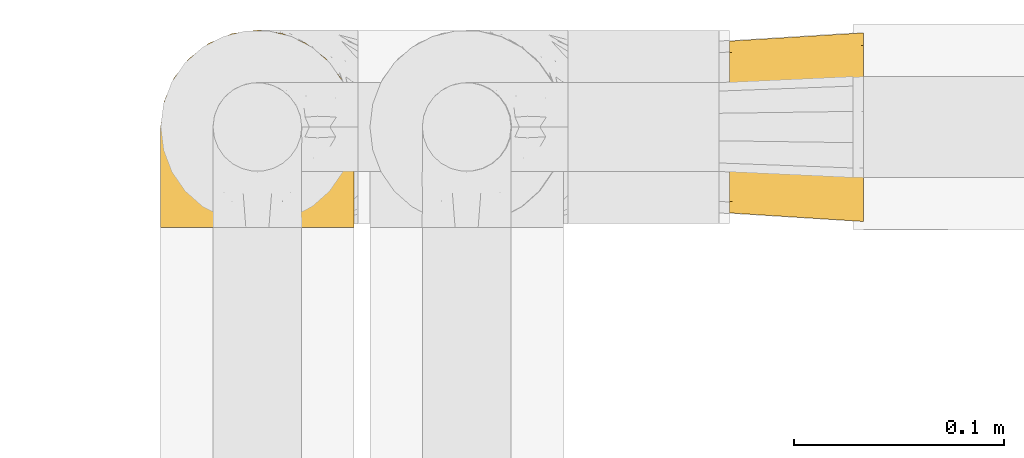
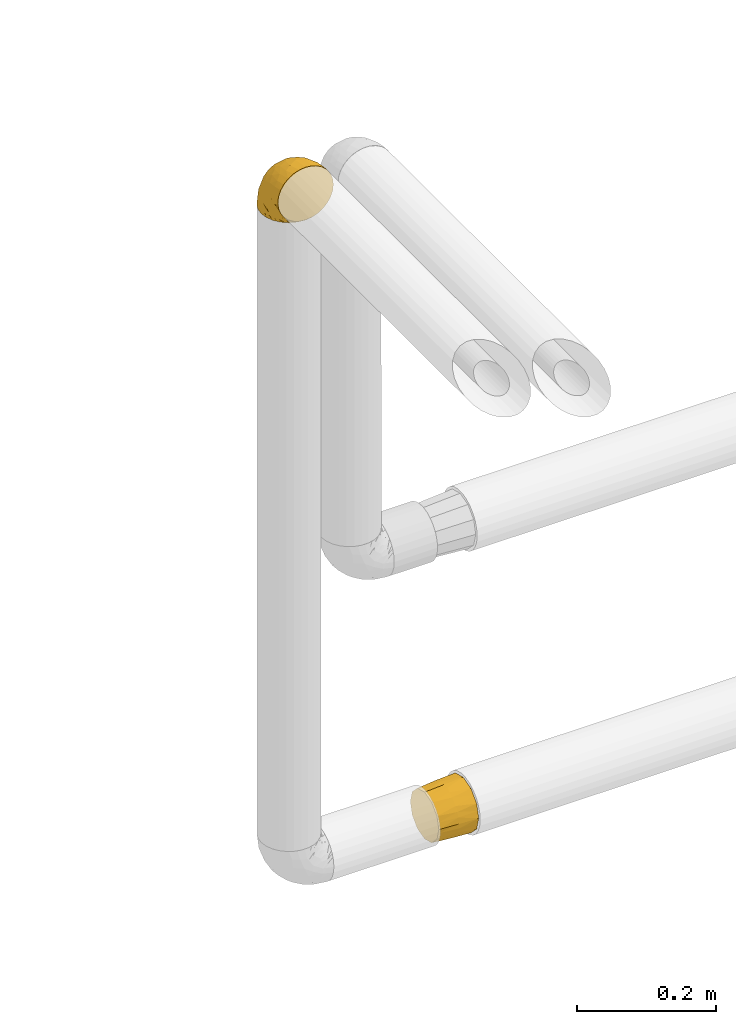
# One storey, part 306 of 827: 2 coverings.
"""IFC2X3 building model written with IfcOpenShell, lengths in millimetres."""

from ifc_helpers import new_model, entity, si_unit, converted_unit, derived_unit, direction, frame, origin, place, context, subcontext, project, spatial, faceted_brep, element, save


model = new_model("IFC2X3")

# Units and contexts
model_context = context("Model", 3, precision=0.01, world=origin(), true_north=direction((6.12303176911189e-17, 1.0)))
body_context = subcontext(model_context, "Body", "Model", "MODEL_VIEW")
ifc_project = project(units=[si_unit("LENGTHUNIT", "METRE", prefix="MILLI"), si_unit("AREAUNIT", "SQUARE_METRE"), si_unit("VOLUMEUNIT", "CUBIC_METRE"), converted_unit("PLANEANGLEUNIT", "DEGREE", entity("IfcRatioMeasure", 0.0174532925199433), si_unit("PLANEANGLEUNIT", "RADIAN"), dimensions=[0, 0, 0, 0, 0, 0, 0]), si_unit("MASSUNIT", "GRAM", prefix="KILO"), derived_unit("MASSDENSITYUNIT", [(si_unit("MASSUNIT", "GRAM", prefix="KILO"), 1), (si_unit("LENGTHUNIT", "METRE"), -3)]), derived_unit("MOMENTOFINERTIAUNIT", [(si_unit("LENGTHUNIT", "METRE"), 4)]), si_unit("TIMEUNIT", "SECOND"), si_unit("FREQUENCYUNIT", "HERTZ"), si_unit("THERMODYNAMICTEMPERATUREUNIT", "DEGREE_CELSIUS"), derived_unit("THERMALTRANSMITTANCEUNIT", [(si_unit("MASSUNIT", "GRAM", prefix="KILO"), 1), (si_unit("THERMODYNAMICTEMPERATUREUNIT", "KELVIN"), -1), (si_unit("TIMEUNIT", "SECOND"), -3)]), derived_unit("VOLUMETRICFLOWRATEUNIT", [(si_unit("LENGTHUNIT", "METRE"), 3), (si_unit("TIMEUNIT", "SECOND"), -1)]), derived_unit("MASSFLOWRATEUNIT", [(si_unit("MASSUNIT", "GRAM", prefix="KILO"), 1), (si_unit("TIMEUNIT", "SECOND"), -1)]), derived_unit("ROTATIONALFREQUENCYUNIT", [(si_unit("TIMEUNIT", "SECOND"), -1)]), si_unit("ELECTRICCURRENTUNIT", "AMPERE"), si_unit("ELECTRICVOLTAGEUNIT", "VOLT"), si_unit("POWERUNIT", "WATT"), si_unit("FORCEUNIT", "NEWTON", prefix="KILO"), si_unit("ILLUMINANCEUNIT", "LUX"), si_unit("LUMINOUSFLUXUNIT", "LUMEN"), si_unit("LUMINOUSINTENSITYUNIT", "CANDELA"), derived_unit("USERDEFINED", [(si_unit("MASSUNIT", "GRAM", prefix="KILO"), -1), (si_unit("LENGTHUNIT", "METRE"), -2), (si_unit("TIMEUNIT", "SECOND"), 3), (si_unit("LUMINOUSFLUXUNIT", "LUMEN"), 1)]), derived_unit("LINEARVELOCITYUNIT", [(si_unit("LENGTHUNIT", "METRE"), 1), (si_unit("TIMEUNIT", "SECOND"), -1)]), si_unit("PRESSUREUNIT", "PASCAL"), derived_unit("USERDEFINED", [(si_unit("LENGTHUNIT", "METRE"), -2), (si_unit("MASSUNIT", "GRAM", prefix="KILO"), 1), (si_unit("TIMEUNIT", "SECOND"), -2)]), derived_unit("LINEARFORCEUNIT", [(si_unit("MASSUNIT", "GRAM", prefix="KILO"), 1), (si_unit("LENGTHUNIT", "METRE"), 1), (si_unit("TIMEUNIT", "SECOND"), -2), (si_unit("LENGTHUNIT", "METRE"), -1)]), derived_unit("PLANARFORCEUNIT", [(si_unit("MASSUNIT", "GRAM", prefix="KILO"), 1), (si_unit("LENGTHUNIT", "METRE"), 1), (si_unit("TIMEUNIT", "SECOND"), -2), (si_unit("LENGTHUNIT", "METRE"), -2)])], contexts=[model_context])

# Site, building, storey
site_placement = place(None, origin())
site = spatial("IfcSite", under=ifc_project, at=site_placement, CompositionType="ELEMENT")
building_placement = place(site_placement, origin())
building = spatial("IfcBuilding", under=site, at=building_placement, CompositionType="ELEMENT")
storey_placement = place(building_placement, frame((0.0, 0.0, 28200.0)))
storey = spatial("IfcBuildingStorey", under=building, at=storey_placement, Name="08", CompositionType="ELEMENT", Elevation=28200.0)

# Coverings
covering_1_placement = place(storey_placement, frame((28192.24, 19466.61, 2949.91)))
element("IfcCovering", 1, at=covering_1_placement, inside=storey, Name=":ADSK_", ObjectType=":ADSK_", PredefinedType="INSULATION", context=body_context, shape_type="Brep", body=[
    faceted_brep([(83.91, 1.6, 78.41), (76.59, 1.6, 85.72), (67.83, 1.6, 91.22), (58.07, 1.6, 94.64), (47.8, 1.6, 95.8), (37.51, 1.6, 94.64), (27.74, 1.6, 91.22), (18.98, 1.6, 85.71), (11.67, 1.6, 78.39), (6.17, 1.6, 69.63), (2.75, 1.6, 59.87), (1.6, 1.6, 49.6), (2.06, 1.6, 45.45), (2.41, 1.6, 42.38), (2.75, 1.6, 39.31), (4.46, 1.6, 34.43), (6.17, 1.6, 29.54), (8.93, 1.6, 25.16), (11.68, 1.6, 20.78), (15.34, 1.6, 17.13), (19.0, 1.6, 13.47), (27.76, 1.6, 7.97), (32.64, 1.6, 6.26), (37.52, 1.6, 4.55), (47.8, 1.6, 3.4), (58.08, 1.6, 4.55), (62.96, 1.6, 6.26), (67.85, 1.6, 7.97), (76.61, 1.6, 13.48), (80.26, 1.6, 17.14), (83.92, 1.6, 20.8), (86.67, 1.6, 25.18), (89.42, 1.6, 29.56), (91.13, 1.6, 34.44), (92.84, 1.6, 39.32), (93.18, 1.6, 42.39), (93.53, 1.6, 45.45), (94.0, 1.6, 49.6), (92.84, 1.6, 59.88), (89.42, 1.6, 69.65), (47.8, 3.4, 1.6), (35.84, 4.97, 1.6), (24.7, 9.58, 1.6), (19.91, 13.26, 1.6), (15.13, 16.93, 1.6), (11.46, 21.71, 1.6), (7.78, 26.5, 1.6), (5.48, 32.07, 1.6), (3.17, 37.64, 1.6), (2.69, 41.25, 1.6), (2.42, 43.34, 1.6), (2.14, 45.42, 1.6), (1.6, 49.6, 1.6), (3.17, 61.55, 1.6), (7.78, 72.7, 1.6), (15.13, 82.26, 1.6), (24.7, 89.61, 1.6), (35.84, 94.22, 1.6), (47.8, 95.8, 1.6), (59.75, 94.22, 1.6), (70.9, 89.61, 1.6), (80.46, 82.26, 1.6), (87.81, 72.7, 1.6), (92.42, 61.55, 1.6), (94.0, 49.6, 1.6), (93.45, 45.42, 1.6), (92.9, 41.25, 1.6), (92.42, 37.64, 1.6), (90.11, 32.07, 1.6), (87.81, 26.5, 1.6), (84.13, 21.71, 1.6), (80.46, 16.93, 1.6), (75.68, 13.26, 1.6), (70.9, 9.58, 1.6), (59.75, 4.97, 1.6), (71.98, 81.55, 36.81), (63.6, 90.4, 23.28), (59.72, 83.0, 45.8), (47.8, 91.18, 30.7), (55.16, 93.13, 21.2), (47.8, 94.0, 12.96), (63.76, 66.19, 66.19), (72.22, 70.92, 54.51), (74.18, 85.95, 17.98), (92.52, 49.74, 36.69), (94.0, 35.54, 35.54), (94.0, 38.14, 31.64), (94.0, 40.74, 27.75), (94.0, 43.34, 23.86), (94.0, 45.94, 19.96), (82.14, 77.59, 22.8), (80.34, 71.17, 42.67), (87.52, 65.81, 33.21), (79.59, 59.03, 59.45), (78.25, 45.85, 71.5), (85.01, 45.79, 62.66), (90.25, 41.42, 54.5), (93.2, 34.51, 47.57), (87.23, 56.04, 48.81), (85.55, 15.15, 74.98), (93.0, 56.51, 18.7), (89.31, 68.39, 15.75), (61.31, 23.33, 91.17), (56.86, 42.86, 85.28), (68.34, 39.42, 82.58), (65.71, 53.58, 75.78), (56.99, 59.17, 74.98), (72.15, 59.06, 67.27), (70.34, 22.63, 87.38), (78.36, 20.55, 82.04), (47.8, 12.96, 94.0), (47.8, 56.96, 77.8), (47.8, 67.38, 67.38), (93.06, 18.72, 56.2), (94.0, 5.33, 48.85), (94.0, 9.07, 48.11), (94.0, 11.79, 47.57), (94.0, 14.51, 47.03), (94.0, 17.24, 46.48), (94.0, 19.96, 45.94), (89.88, 21.03, 65.78), (94.0, 46.48, 17.24), (94.0, 47.03, 14.51), (94.0, 47.57, 11.79), (94.0, 48.11, 9.07), (94.0, 48.48, 7.2), (94.0, 48.85, 5.33), (47.8, 30.7, 91.18), (94.0, 23.86, 43.34), (94.0, 27.75, 40.74), (94.0, 31.64, 38.14), (83.7, 31.26, 72.73), (47.8, 77.8, 56.96), (55.9, 72.75, 62.23), (47.8, 43.83, 84.49), (47.8, 84.49, 43.83), (81.75, 14.58, 12.05), (86.43, 16.17, 18.95), (79.8, 10.82, 13.02), (69.84, 4.64, 8.34), (79.5, 7.71, 14.63), (88.08, 25.13, 11.09), (91.6, 32.66, 13.66), (92.93, 34.94, 20.08), (92.43, 36.76, 9.61), (93.24, 40.48, 9.48), (93.36, 39.25, 16.1), (57.25, 3.69, 3.42), (89.41, 13.99, 26.63), (92.89, 21.85, 33.72), (92.66, 17.93, 34.77), (79.58, 15.11, 6.75), (86.51, 21.14, 13.31), (83.91, 7.21, 19.94), (88.76, 9.47, 27.05), (90.94, 32.27, 8.67), (91.94, 25.68, 26.11), (91.98, 22.18, 29.3), (82.79, 18.79, 6.32), (93.16, 10.12, 39.92), (73.94, 10.45, 6.04), (91.89, 11.29, 34.4), (47.8, 2.87, 2.87), (92.22, 31.16, 20.92), (86.29, 12.7, 21.11), (88.56, 6.31, 27.43), (87.72, 25.62, 7.54), (88.33, 21.18, 18.45), (92.18, 28.81, 23.88), (71.78, 7.45, 7.77), (9.09, 21.14, 13.3), (7.51, 25.13, 11.09), (12.8, 18.79, 6.33), (1.6, 48.11, 9.07), (1.6, 48.85, 5.33), (1.6, 47.03, 14.51), (1.6, 47.57, 11.79), (38.35, 3.69, 3.42), (23.84, 7.44, 7.76), (1.6, 14.51, 47.03), (1.6, 11.79, 47.57), (1.6, 5.33, 48.85), (1.6, 9.07, 48.11), (16.1, 7.71, 14.62), (6.84, 9.47, 27.03), (2.66, 34.94, 20.08), (3.37, 31.16, 20.92), (1.6, 40.74, 27.75), (1.6, 38.14, 31.64), (3.16, 36.76, 9.61), (2.35, 40.48, 9.48), (25.77, 4.63, 8.33), (16.02, 15.11, 6.74), (13.85, 14.58, 12.04), (1.6, 43.34, 23.86), (1.6, 45.94, 19.96), (2.23, 39.25, 16.1), (11.69, 7.21, 19.93), (9.31, 12.69, 21.1), (2.43, 10.14, 39.92), (2.71, 21.81, 33.68), (3.61, 22.19, 29.28), (6.18, 14.0, 26.62), (3.66, 25.69, 26.08), (9.17, 16.17, 18.93), (6.77, 6.66, 27.87), (2.93, 17.92, 34.75), (21.66, 10.45, 6.04), (1.6, 31.64, 38.14), (16.09, 10.64, 12.79), (3.7, 11.31, 34.41), (1.6, 19.96, 45.94), (1.6, 23.86, 43.34), (1.6, 27.75, 40.74), (3.99, 32.66, 13.66), (1.6, 46.48, 17.24), (4.65, 32.27, 8.67), (1.6, 35.54, 35.54), (3.43, 28.77, 23.83), (7.27, 21.17, 18.43), (9.46, 23.36, 6.03), (1.6, 17.24, 46.48), (2.4, 47.58, 34.52), (40.43, 93.13, 21.2), (13.57, 77.44, 23.82), (11.3, 66.78, 41.32), (18.65, 71.68, 47.62), (27.26, 74.96, 52.66), (23.61, 81.55, 36.81), (3.07, 36.7, 49.75), (2.69, 56.9, 19.07), (35.87, 83.0, 45.8), (31.99, 90.4, 23.28), (6.71, 67.83, 21.35), (21.41, 85.95, 17.98), (27.24, 39.41, 82.57), (34.26, 23.33, 91.17), (38.73, 42.87, 85.27), (26.97, 53.92, 73.89), (31.83, 66.19, 66.19), (23.4, 64.12, 62.43), (6.91, 33.13, 63.53), (3.4, 23.1, 58.45), (5.84, 16.98, 67.16), (35.73, 55.72, 76.72), (39.69, 72.75, 62.22), (17.6, 23.77, 81.54), (10.38, 18.41, 74.8), (20.6, 43.7, 75.83), (5.36, 54.53, 41.45), (24.84, 17.73, 88.2), (13.87, 38.98, 71.6), (9.06, 50.28, 56.23), (15.99, 59.02, 59.44)], [[[0, 1, 2, 3, 4, 5, 6, 7, 8, 9, 10, 11, 12, 13, 14, 15, 16, 17, 18, 19, 20, 21, 22, 23, 24, 25, 26, 27, 28, 29, 30, 31, 32, 33, 34, 35, 36, 37, 38, 39]], [[40, 41, 42, 43, 44, 45, 46, 47, 48, 49, 50, 51, 52, 53, 54, 55, 56, 57, 58, 59, 60, 61, 62, 63, 64, 65, 66, 67, 68, 69, 70, 71, 72, 73, 74]], [[75, 76, 77]], [[78, 79, 80]], [[77, 81, 82]], [[76, 75, 83]], [[84, 85, 86, 87, 88, 89]], [[90, 91, 92]], [[76, 60, 59]], [[93, 94, 95]], [[90, 62, 61]], [[83, 61, 60]], [[96, 97, 84]], [[98, 93, 95]], [[0, 39, 99]], [[100, 84, 89]], [[62, 101, 63]], [[2, 102, 3]], [[92, 84, 100]], [[103, 102, 104]], [[103, 105, 106]], [[93, 107, 94]], [[1, 108, 2]], [[92, 101, 90]], [[108, 1, 109]], [[102, 110, 3]], [[93, 82, 107]], [[102, 108, 104]], [[111, 106, 112]], [[109, 0, 99]], [[113, 37, 114, 115, 116, 117, 118, 119]], [[120, 38, 113]], [[100, 89, 121, 122, 123, 124, 125, 126, 64]], [[127, 102, 103]], [[97, 119, 128, 129, 130, 85]], [[99, 120, 131]], [[132, 133, 77]], [[59, 80, 79]], [[1, 0, 109]], [[98, 84, 92]], [[94, 109, 131]], [[120, 39, 38]], [[93, 91, 82]], [[104, 94, 105]], [[97, 113, 119]], [[95, 120, 96]], [[83, 90, 61]], [[91, 93, 98]], [[64, 63, 100]], [[100, 63, 101]], [[77, 76, 79]], [[133, 106, 81]], [[84, 97, 85]], [[113, 96, 120]], [[113, 97, 96]], [[37, 113, 38]], [[110, 102, 127]], [[110, 4, 3]], [[103, 111, 134, 127]], [[90, 75, 91]], [[82, 81, 107]], [[91, 75, 82]], [[77, 82, 75]], [[76, 83, 60]], [[90, 83, 75]], [[105, 107, 81]], [[94, 131, 95]], [[105, 94, 107]], [[109, 94, 104]], [[120, 95, 131]], [[98, 95, 96]], [[84, 98, 96]], [[98, 92, 91]], [[106, 105, 81]], [[103, 104, 105]], [[112, 106, 133]], [[103, 106, 111]], [[112, 133, 132]], [[81, 77, 133]], [[77, 78, 135, 132]], [[120, 99, 39]], [[109, 99, 131]], [[59, 58, 80]], [[59, 79, 76]], [[90, 101, 62]], [[100, 101, 92]], [[2, 108, 102]], [[109, 104, 108]], [[78, 77, 79]], [[136, 137, 138]], [[27, 139, 140]], [[141, 142, 143]], [[144, 145, 121]], [[146, 89, 88]], [[147, 139, 25]], [[148, 149, 150]], [[136, 151, 152]], [[147, 40, 74]], [[24, 147, 25]], [[153, 148, 154]], [[33, 116, 34]], [[73, 72, 151]], [[114, 37, 36, 35, 34, 116, 115]], [[146, 155, 144]], [[156, 85, 130]], [[157, 149, 148]], [[151, 158, 152]], [[117, 33, 159]], [[29, 153, 154]], [[160, 74, 73]], [[161, 128, 119]], [[65, 64, 126, 125, 124, 123, 122, 67, 66]], [[162, 147, 24]], [[27, 140, 28]], [[149, 129, 150]], [[139, 27, 26, 25]], [[68, 144, 69]], [[129, 128, 150]], [[163, 87, 86]], [[130, 129, 149]], [[122, 145, 67]], [[153, 164, 148]], [[161, 119, 159]], [[165, 30, 154]], [[150, 154, 148]], [[128, 161, 150]], [[30, 165, 31]], [[145, 144, 68]], [[89, 146, 144]], [[87, 163, 143]], [[166, 155, 142]], [[88, 87, 143]], [[161, 154, 150]], [[154, 30, 29]], [[29, 28, 153]], [[28, 140, 153]], [[164, 153, 140]], [[140, 137, 164]], [[157, 148, 164]], [[156, 130, 157]], [[164, 137, 157]], [[157, 137, 156]], [[167, 137, 136]], [[168, 85, 156]], [[152, 168, 167]], [[167, 168, 156]], [[163, 152, 141]], [[71, 158, 72]], [[152, 167, 136]], [[88, 142, 146]], [[144, 155, 69]], [[146, 142, 155]], [[70, 166, 71]], [[142, 141, 166]], [[70, 69, 155]], [[141, 158, 71]], [[160, 73, 151]], [[138, 137, 140]], [[160, 136, 169]], [[136, 160, 151]], [[74, 160, 169]], [[152, 158, 141]], [[151, 72, 158]], [[168, 152, 163]], [[137, 167, 156]], [[163, 86, 168]], [[85, 168, 86]], [[116, 33, 117]], [[130, 149, 157]], [[67, 145, 68]], [[121, 89, 144]], [[145, 122, 121]], [[40, 147, 162]], [[169, 147, 74]], [[159, 33, 32]], [[161, 159, 32]], [[159, 119, 118, 117]], [[139, 147, 169]], [[139, 169, 138]], [[161, 32, 31]], [[141, 143, 163]], [[88, 143, 142]], [[71, 166, 141]], [[155, 166, 70]], [[139, 138, 140]], [[169, 136, 138]], [[154, 161, 165]], [[161, 31, 165]], [[170, 171, 172]], [[173, 174, 52, 51, 50, 49, 48, 175, 176]], [[177, 178, 41]], [[179, 15, 180]], [[12, 11, 181, 182, 180, 14, 13]], [[183, 21, 20]], [[19, 18, 184]], [[185, 186, 187]], [[186, 188, 187]], [[43, 172, 44]], [[189, 190, 47]], [[23, 22, 21, 191]], [[170, 192, 193]], [[40, 162, 177]], [[194, 195, 196]], [[24, 23, 177]], [[197, 198, 183]], [[199, 15, 179]], [[47, 46, 189]], [[200, 201, 202]], [[201, 203, 204]], [[205, 206, 184]], [[207, 41, 178]], [[16, 15, 199]], [[14, 180, 15]], [[202, 201, 198]], [[208, 201, 200]], [[162, 24, 177]], [[48, 47, 190]], [[196, 195, 189]], [[197, 184, 202]], [[204, 193, 209]], [[210, 211, 212]], [[206, 212, 213]], [[205, 17, 210]], [[184, 206, 202]], [[210, 212, 206]], [[185, 194, 214]], [[189, 215, 190]], [[216, 45, 214]], [[186, 171, 170]], [[189, 216, 196]], [[197, 20, 19]], [[194, 185, 187]], [[197, 183, 20]], [[184, 197, 19]], [[197, 202, 198]], [[206, 200, 202]], [[204, 183, 198]], [[201, 208, 203]], [[203, 208, 217]], [[204, 198, 201]], [[217, 188, 218]], [[193, 219, 170]], [[171, 186, 185]], [[170, 218, 186]], [[170, 219, 218]], [[42, 207, 192]], [[171, 220, 172]], [[216, 189, 46]], [[214, 194, 196]], [[44, 220, 45]], [[214, 196, 216]], [[216, 46, 45]], [[214, 45, 220]], [[192, 43, 42]], [[204, 203, 219]], [[207, 193, 192]], [[209, 193, 178]], [[41, 207, 42]], [[193, 207, 178]], [[43, 192, 172]], [[170, 172, 192]], [[204, 219, 193]], [[219, 203, 218]], [[217, 218, 203]], [[188, 186, 218]], [[206, 213, 200]], [[208, 200, 213]], [[199, 210, 16]], [[215, 189, 195]], [[215, 175, 190]], [[175, 48, 190]], [[199, 179, 221, 211]], [[210, 199, 211]], [[23, 191, 177]], [[40, 177, 41]], [[183, 209, 191]], [[183, 191, 21]], [[191, 178, 177]], [[205, 18, 17]], [[17, 16, 210]], [[171, 185, 214]], [[172, 220, 44]], [[214, 220, 171]], [[191, 209, 178]], [[204, 209, 183]], [[206, 205, 210]], [[18, 205, 184]], [[222, 195, 194, 187, 188, 217]], [[57, 223, 80]], [[224, 225, 226]], [[226, 227, 228]], [[229, 217, 208, 213, 212, 211]], [[230, 52, 174, 173, 176, 175, 215, 195]], [[231, 232, 228]], [[231, 78, 223]], [[223, 57, 232]], [[224, 233, 225]], [[233, 54, 53]], [[234, 232, 56]], [[56, 55, 234]], [[234, 224, 228]], [[235, 236, 237]], [[224, 55, 54]], [[238, 239, 240]], [[52, 230, 53]], [[241, 242, 243]], [[239, 244, 245]], [[11, 10, 242]], [[236, 6, 5]], [[7, 246, 8]], [[8, 247, 9]], [[238, 248, 235]], [[222, 229, 249]], [[242, 211, 221, 179, 180, 182, 181, 11]], [[233, 53, 230]], [[111, 112, 244]], [[250, 6, 236]], [[247, 251, 241]], [[6, 250, 7]], [[127, 236, 110]], [[249, 229, 252]], [[247, 8, 246]], [[235, 246, 250]], [[236, 5, 110]], [[235, 244, 238]], [[237, 236, 127]], [[243, 9, 247]], [[252, 229, 241]], [[56, 232, 57]], [[222, 230, 195]], [[225, 249, 252]], [[249, 233, 230]], [[54, 233, 224]], [[231, 228, 227]], [[245, 132, 231]], [[249, 225, 233]], [[226, 225, 253]], [[235, 250, 236]], [[246, 7, 250]], [[251, 247, 246]], [[243, 247, 241]], [[248, 246, 235]], [[252, 251, 253]], [[229, 222, 217]], [[230, 222, 249]], [[5, 4, 110]], [[237, 127, 134, 111]], [[238, 244, 239]], [[224, 234, 55]], [[232, 234, 228]], [[242, 241, 229]], [[10, 9, 243]], [[211, 242, 229]], [[10, 243, 242]], [[80, 223, 78]], [[80, 58, 57]], [[231, 223, 232]], [[227, 240, 239]], [[224, 226, 228]], [[240, 226, 253]], [[227, 239, 245]], [[226, 240, 227]], [[251, 248, 253]], [[240, 253, 248]], [[244, 235, 237]], [[237, 111, 244]], [[132, 245, 112]], [[112, 245, 244]], [[135, 78, 231, 132]], [[227, 245, 231]], [[248, 238, 240]], [[246, 248, 251]], [[251, 252, 241]], [[225, 252, 253]]]),
])
covering_2_placement = place(storey_placement, frame((28465.22, 19469.54, 1753.4)))
element("IfcCovering", 2, at=covering_2_placement, inside=storey, Name=":ADSK_", ObjectType=":ADSK_", PredefinedType="INSULATION", context=body_context, shape_type="Brep", body=[
    faceted_brep([(64.0, 15.86, 77.33), (64.0, 7.62, 69.1), (64.0, 4.61, 57.85), (64.0, 1.6, 46.6), (64.0, 4.61, 35.35), (64.0, 7.62, 24.1), (64.0, 15.86, 15.86), (64.0, 24.1, 7.62), (64.0, 35.35, 4.61), (64.0, 46.6, 1.6), (64.0, 57.85, 4.61), (64.0, 69.1, 7.62), (64.0, 77.33, 15.86), (64.0, 85.57, 24.1), (64.0, 88.58, 35.35), (64.0, 91.6, 46.6), (64.0, 88.58, 57.85), (64.0, 85.57, 69.1), (64.0, 77.33, 77.33), (64.0, 69.1, 85.57), (64.0, 57.85, 88.58), (64.0, 46.6, 91.6), (64.0, 35.35, 88.58), (64.0, 24.1, 85.57), (0.0, 67.17, 82.1), (0.0, 74.67, 74.6), (0.0, 82.17, 67.1), (0.0, 85.58, 54.39), (0.0, 87.67, 46.6), (0.0, 84.92, 36.35), (0.0, 82.17, 26.1), (0.0, 74.67, 18.59), (0.0, 67.17, 11.09), (0.0, 54.46, 7.68), (0.0, 46.67, 5.6), (0.0, 36.42, 8.34), (0.0, 26.17, 11.09), (0.0, 18.66, 18.59), (0.0, 11.16, 26.1), (0.0, 7.75, 38.8), (0.0, 5.67, 46.6), (0.0, 8.41, 56.85), (0.0, 11.16, 67.1), (0.0, 18.66, 74.6), (0.0, 26.17, 82.1), (0.0, 38.87, 85.51), (0.0, 46.67, 87.6), (0.0, 56.92, 84.85), (32.0, 6.9, 30.14), (33.43, 4.37, 38.19), (32.84, 3.58, 46.6), (32.0, 11.18, 22.25), (32.0, 35.94, 4.94), (32.0, 20.45, 12.48), (32.0, 28.11, 7.79), (32.84, 46.63, 3.54), (32.0, 63.09, 6.87), (33.43, 55.04, 4.33), (32.0, 70.97, 11.15), (32.0, 88.28, 35.91), (32.0, 80.74, 20.42), (32.0, 85.44, 28.07), (32.84, 89.68, 46.6), (32.0, 86.36, 63.05), (33.43, 88.89, 55.0), (32.0, 82.08, 70.94), (32.0, 57.32, 88.25), (32.0, 72.81, 80.71), (32.0, 65.16, 85.4), (32.84, 46.63, 89.65), (32.0, 30.17, 86.32), (33.43, 38.22, 88.86), (32.0, 22.29, 82.04), (32.0, 4.98, 57.28), (32.0, 12.52, 72.77), (32.0, 7.83, 65.12)], [[[0, 1, 2, 3, 4, 5, 6, 7, 8, 9, 10, 11, 12, 13, 14, 15, 16, 17, 18, 19, 20, 21, 22, 23]], [[24, 25, 26, 27, 28, 29, 30, 31, 32, 33, 34, 35, 36, 37, 38, 39, 40, 41, 42, 43, 44, 45, 46, 47]], [[39, 48, 49]], [[39, 50, 40]], [[48, 39, 38]], [[5, 4, 48]], [[51, 5, 48]], [[48, 4, 49]], [[9, 8, 52]], [[53, 51, 37]], [[51, 48, 38]], [[7, 53, 54]], [[54, 53, 36]], [[37, 36, 53]], [[51, 38, 37]], [[50, 49, 3]], [[53, 6, 51]], [[6, 5, 51]], [[6, 53, 7]], [[52, 8, 54]], [[54, 35, 52]], [[54, 36, 35]], [[3, 49, 4]], [[8, 7, 54]], [[34, 55, 9, 52]], [[39, 49, 50]], [[34, 52, 35]], [[33, 56, 57]], [[33, 55, 34]], [[56, 33, 32]], [[11, 10, 56]], [[58, 11, 56]], [[56, 10, 57]], [[15, 14, 59]], [[60, 58, 31]], [[58, 56, 32]], [[13, 60, 61]], [[61, 60, 30]], [[31, 30, 60]], [[58, 32, 31]], [[55, 57, 9]], [[60, 12, 58]], [[12, 11, 58]], [[12, 60, 13]], [[59, 14, 61]], [[61, 29, 59]], [[61, 30, 29]], [[9, 57, 10]], [[14, 13, 61]], [[28, 62, 15, 59]], [[33, 57, 55]], [[28, 59, 29]], [[27, 63, 64]], [[27, 62, 28]], [[63, 27, 26]], [[17, 16, 63]], [[65, 17, 63]], [[63, 16, 64]], [[21, 20, 66]], [[67, 65, 25]], [[65, 63, 26]], [[19, 67, 68]], [[68, 67, 24]], [[25, 24, 67]], [[65, 26, 25]], [[62, 64, 15]], [[67, 18, 65]], [[18, 17, 65]], [[18, 67, 19]], [[66, 20, 68]], [[68, 47, 66]], [[68, 24, 47]], [[15, 64, 16]], [[20, 19, 68]], [[46, 69, 21, 66]], [[27, 64, 62]], [[46, 66, 47]], [[45, 70, 71]], [[45, 69, 46]], [[70, 45, 44]], [[23, 22, 70]], [[72, 23, 70]], [[70, 22, 71]], [[3, 2, 73]], [[74, 72, 43]], [[72, 70, 44]], [[1, 74, 75]], [[75, 74, 42]], [[43, 42, 74]], [[72, 44, 43]], [[69, 71, 21]], [[74, 0, 72]], [[0, 23, 72]], [[0, 74, 1]], [[73, 2, 75]], [[75, 41, 73]], [[75, 42, 41]], [[21, 71, 22]], [[2, 1, 75]], [[40, 50, 3, 73]], [[45, 71, 69]], [[40, 73, 41]]]),
])

save(model, "model.ifc")
